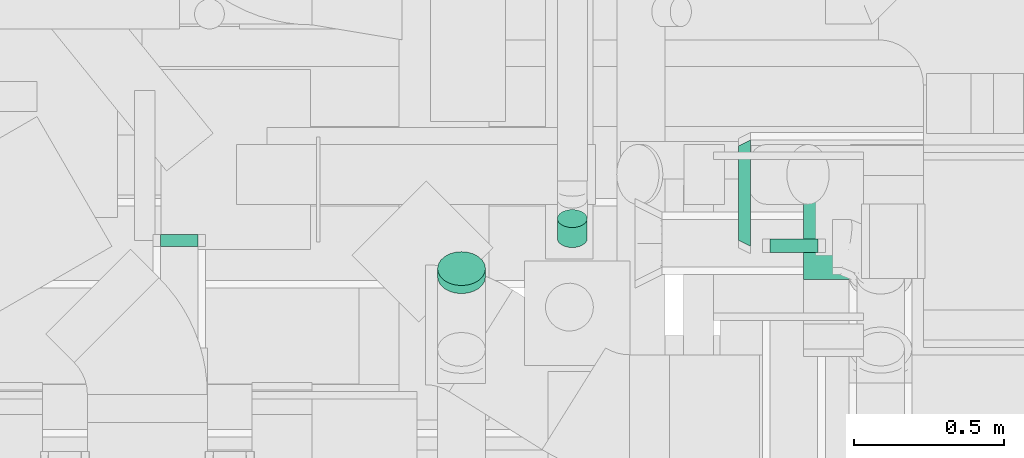
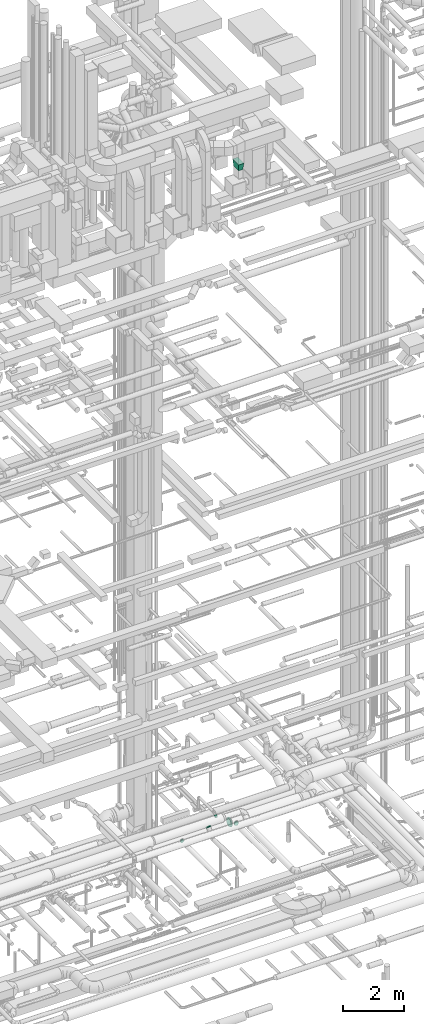
# One storey, part 328 of 337: 6 flow fittings.
"""IFC2X3 building model written with IfcOpenShell, lengths in millimetres."""

import ifcopenshell
import ifcopenshell.guid

model = None  # the IFC model being written
_history = None  # IfcOwnerHistory: only IFC2X3 demands one
_inside = {}  # id of a spatial element -> (the spatial element, [elements in it])
_under = {}  # id of a project, library or spatial element -> (it, [spatial elements below it])
_declared = {}  # id of a project -> (the project, [libraries it declares])
_typed = {}  # id of a type object -> (the type object, [elements of that type])
_made_of = {}  # id of a material, layer set ... -> (it, [elements and type objects made of it])


def new_model(schema):
    """Start an empty IFC model of exactly this schema.

    Asked for "IFC4X3", IfcOpenShell would pick the latest addendum, in which some entities
    have other attributes; the version numbers below select the first issue.
    IFC2X3 requires an IfcOwnerHistory on every rooted entity: one is made here for all.
    """
    global model, _history
    if schema == "IFC4X3":
        model = ifcopenshell.file(schema_version=(4, 3, 0, 0))
    else:
        model = ifcopenshell.file(schema=schema)
    _inside.clear()
    _under.clear()
    _declared.clear()
    _typed.clear()
    _made_of.clear()
    _history = None
    if model.schema == "IFC2X3":
        org = make("IfcOrganization", Name="unknown")
        user = make(
            "IfcPersonAndOrganization",
            ThePerson=make("IfcPerson", FamilyName="unknown"),
            TheOrganization=org,
        )
        app = make(
            "IfcApplication",
            ApplicationDeveloper=org,
            Version="unknown",
            ApplicationFullName="unknown",
            ApplicationIdentifier="unknown",
        )
        _history = make(
            "IfcOwnerHistory",
            OwningUser=user,
            OwningApplication=app,
            ChangeAction="ADDED",
            CreationDate=0,
        )
    return model


def make(cls, **values):
    """One entity of the class cls with the attributes given. An attribute that is None is left unset."""
    return model.create_entity(
        cls, **{name: value for name, value in values.items() if value is not None}
    )


def entity(cls, *values):
    """Any entity or typed value of the class cls, its attributes in the order of the schema. None: left unset."""
    e = model.create_entity(cls)
    for i, value in enumerate(values):
        if value is not None:
            e[i] = value
    return e


def rooted(cls, **values):
    """An entity with a GlobalId (a new one), such as an element, a storey or a relation."""
    return make(cls, GlobalId=ifcopenshell.guid.new(), OwnerHistory=_history, **values)


def si_unit(unit_type, name, prefix=None):
    """IfcSIUnit, for example si_unit("LENGTHUNIT", "METRE", prefix="MILLI")."""
    return make("IfcSIUnit", UnitType=unit_type, Prefix=prefix, Name=name)


def converted_unit(unit_type, name, factor, base, dimensions=None, offset=None):
    """IfcConversionBasedUnit, such as the inch: factor (a typed value) times the base unit."""
    return make(
        "IfcConversionBasedUnit"
        if offset is None
        else "IfcConversionBasedUnitWithOffset",
        ConversionOffset=offset,
        Dimensions=None
        if dimensions is None
        else entity("IfcDimensionalExponents", *dimensions),
        UnitType=unit_type,
        Name=name,
        ConversionFactor=make(
            "IfcMeasureWithUnit", ValueComponent=factor, UnitComponent=base
        ),
    )


def derived_unit(unit_type, elements):
    """IfcDerivedUnit: a product of units, each with its exponent."""
    return make(
        "IfcDerivedUnit",
        Elements=[
            make("IfcDerivedUnitElement", Unit=unit, Exponent=power)
            for unit, power in elements
        ],
        UnitType=unit_type,
    )


def assignment(units):
    """IfcUnitAssignment: the units of a project."""
    return None if units is None else make("IfcUnitAssignment", Units=units)


def point(xyz):
    """IfcCartesianPoint."""
    return None if xyz is None else make("IfcCartesianPoint", Coordinates=xyz)


def direction(xyz):
    """IfcDirection."""
    return None if xyz is None else make("IfcDirection", DirectionRatios=xyz)


def frame(location, z_axis=None, x_axis=None):
    """IfcAxis2Placement3D, a coordinate frame: its origin and axes. An axis left out is left unset."""
    return make(
        "IfcAxis2Placement3D",
        Location=point(location),
        Axis=direction(z_axis),
        RefDirection=direction(x_axis),
    )


def origin():
    """The frame at (0, 0, 0) with its axes left unset."""
    return frame((0.0, 0.0, 0.0))


def place(relative_to, where):
    """IfcLocalPlacement: puts the frame where relative to a parent placement (None: the world)."""
    return make(
        "IfcLocalPlacement", PlacementRelTo=relative_to, RelativePlacement=where
    )


def context(
    kind, dimensions, precision=None, world=None, true_north=None, identifier=None
):
    """IfcGeometricRepresentationContext, for example the 3D "Model" context."""
    return make(
        "IfcGeometricRepresentationContext",
        ContextIdentifier=identifier,
        ContextType=kind,
        CoordinateSpaceDimension=dimensions,
        Precision=precision,
        WorldCoordinateSystem=world,
        TrueNorth=true_north,
    )


def subcontext(parent, identifier, kind, view, scale=None):
    """IfcGeometricRepresentationSubContext, for example "Body" below "Model"."""
    return make(
        "IfcGeometricRepresentationSubContext",
        ContextIdentifier=identifier,
        ContextType=kind,
        ParentContext=parent,
        TargetScale=scale,
        TargetView=view,
    )


def project(units=None, contexts=None):
    """IfcProject with its units and contexts."""
    return rooted(
        "IfcProject",
        Name="project",
        RepresentationContexts=contexts,
        UnitsInContext=assignment(units),
    )


def spatial(cls, under=None, at=None, **own):
    """A site, building, storey or space (cls), placed at a placement, below another one or the project."""
    s = rooted(cls, ObjectPlacement=at, **own)
    if under is not None:
        _under.setdefault(under.id(), (under, []))[1].append(s)
    return s


def faces_of(points, faces, orient=None, outer=None):
    """IfcFace entities. A face is a list of loops; a loop is a list of indices into points, from 0.

    orient and outer hold one flag for each loop. By default every Orientation is true, the
    first loop of a face is its IfcFaceOuterBound and the others are IfcFaceBound.
    """
    made = []
    for i, loops in enumerate(faces):
        bounds = []
        for j, loop in enumerate(loops):
            is_outer = j == 0 if outer is None else outer[i][j]
            bounds.append(
                make(
                    "IfcFaceOuterBound" if is_outer else "IfcFaceBound",
                    Bound=make("IfcPolyLoop", Polygon=[points[k] for k in loop]),
                    Orientation=True if orient is None else orient[i][j],
                )
            )
        made.append(make("IfcFace", Bounds=bounds))
    return made


def faceted_brep(points, faces, orient=None, outer=None, voids=None):
    """IfcFacetedBrep: a solid bounded by flat faces; with voids (closed shells), ...WithVoids."""
    shared = [point(p) for p in points]
    hull = make("IfcClosedShell", CfsFaces=faces_of(shared, faces, orient, outer))
    if voids is None:
        return make("IfcFacetedBrep", Outer=hull)
    return make(
        "IfcFacetedBrepWithVoids",
        Outer=hull,
        Voids=[
            make(cls, CfsFaces=faces_of(shared, fs, o, b)) for cls, fs, o, b in voids
        ],
    )


def shape(context_of_items, identifier, shape_type, items):
    """IfcShapeRepresentation: the items that make up one representation, for example the "Body"."""
    return make(
        "IfcShapeRepresentation",
        ContextOfItems=context_of_items,
        RepresentationIdentifier=identifier,
        RepresentationType=shape_type,
        Items=items,
    )


def source(mapping_origin, context_of_items, identifier, shape_type, items):
    """IfcRepresentationMap: a shape defined once, which mapped items show again and again."""
    return make(
        "IfcRepresentationMap",
        MappingOrigin=mapping_origin,
        MappedRepresentation=shape(context_of_items, identifier, shape_type, items),
    )


def transform(
    local_origin,
    x_axis=None,
    y_axis=None,
    z_axis=None,
    scale=None,
    scale2=None,
    scale3=None,
    uniform=True,
):
    """IfcCartesianTransformationOperator3D, or its non-uniform kind. x_axis, y_axis, z_axis: its Axis1, 2, 3."""
    if uniform:
        return make(
            "IfcCartesianTransformationOperator3D",
            Axis1=direction(x_axis),
            Axis2=direction(y_axis),
            LocalOrigin=point(local_origin),
            Scale=scale,
            Axis3=direction(z_axis),
        )
    return make(
        "IfcCartesianTransformationOperator3DnonUniform",
        Axis1=direction(x_axis),
        Axis2=direction(y_axis),
        LocalOrigin=point(local_origin),
        Scale=scale,
        Axis3=direction(z_axis),
        Scale2=scale2,
        Scale3=scale3,
    )


def mapped(mapping_source, mapping_target):
    """IfcMappedItem: shows the shape of a source again, moved by a transform."""
    return make(
        "IfcMappedItem", MappingSource=mapping_source, MappingTarget=mapping_target
    )


def material(Name=None, Category=None):
    """IfcMaterial."""
    return make("IfcMaterial", Name=Name, Category=Category)


def made_of(thing, what):
    """Note that an element or type object is made of a material, layer set ...; save() writes the relation."""
    if what is not None:
        _made_of.setdefault(what.id(), (what, []))[1].append(thing)
    return thing


def type_object(cls, material=None, **own):
    """A type object (cls), such as IfcWallType, which elements share."""
    return made_of(rooted(cls, **own), material)


def type_shapes(of_type, sources):
    """Give a type object the sources (RepresentationMaps) that its elements show as mapped items."""
    of_type.RepresentationMaps = sources


def element(
    cls,
    number,
    at=None,
    inside=None,
    cuts=None,
    type_object=None,
    material=None,
    context=None,
    identifier="Body",
    shape_type=None,
    held_by="IfcProductDefinitionShape",
    body=None,
    shapes=None,
    **own,
):
    """One element of the class cls, such as IfcWall. Its Tag is "e" and its number.

    at: its placement. inside: the storey or other place that contains it. cuts: it is an
    opening in that element (IfcRelVoidsElement). A single representation is given by context,
    identifier, shape_type and body (its items); several are given by shapes. held_by: the class
    of the entity that holds the representations. save() writes the other relations.
    """
    e = rooted(cls, Tag="e%d" % number, ObjectPlacement=at, **own)
    if body is not None:
        shapes = [shape(context, identifier, shape_type, body)]
    if shapes is not None:
        e.Representation = make(held_by, Representations=shapes)
    if inside is not None:
        _inside.setdefault(inside.id(), (inside, []))[1].append(e)
    if cuts is not None:
        rooted(
            "IfcRelVoidsElement", RelatingBuildingElement=cuts, RelatedOpeningElement=e
        )
    if type_object is not None:
        _typed.setdefault(type_object.id(), (type_object, []))[1].append(e)
    return made_of(e, material)


def aggregate(whole, parts):
    """IfcRelAggregates: a whole, such as a stair, and the parts it consists of."""
    return rooted("IfcRelAggregates", RelatingObject=whole, RelatedObjects=parts)


def save(model, path):
    """Write the relations noted so far, then the file.

    IfcRelAggregates (storeys below a building ...), IfcRelContainedInSpatialStructure (elements
    in a storey), IfcRelDefinesByType, IfcRelAssociatesMaterial and IfcRelDeclares: one each for
    every whole, place, type object, material and project.
    """
    for whole, parts in _under.values():
        aggregate(whole, parts)
    for where, things in _inside.values():
        rooted(
            "IfcRelContainedInSpatialStructure",
            RelatedElements=things,
            RelatingStructure=where,
        )
    for kind, things in _typed.values():
        rooted("IfcRelDefinesByType", RelatedObjects=things, RelatingType=kind)
    for what, things in _made_of.values():
        rooted("IfcRelAssociatesMaterial", RelatedObjects=things, RelatingMaterial=what)
    for by, libraries in _declared.values():
        rooted("IfcRelDeclares", RelatingContext=by, RelatedDefinitions=libraries)
    model.write(path)


model = new_model("IFC2X3")

# Units and contexts
model_context = context("Model", 3, precision=0.01, world=origin(), true_north=direction((6.12303176911189e-17, 1.0)))
body_context = subcontext(model_context, "Body", "Model", "MODEL_VIEW")
ifc_project = project(units=[si_unit("LENGTHUNIT", "METRE", prefix="MILLI"), si_unit("AREAUNIT", "SQUARE_METRE"), si_unit("VOLUMEUNIT", "CUBIC_METRE"), converted_unit("PLANEANGLEUNIT", "DEGREE", entity("IfcRatioMeasure", 0.0174532925199433), si_unit("PLANEANGLEUNIT", "RADIAN"), dimensions=[0, 0, 0, 0, 0, 0, 0]), si_unit("MASSUNIT", "GRAM", prefix="KILO"), derived_unit("MASSDENSITYUNIT", [(si_unit("MASSUNIT", "GRAM", prefix="KILO"), 1), (si_unit("LENGTHUNIT", "METRE"), -3)]), derived_unit("MOMENTOFINERTIAUNIT", [(si_unit("LENGTHUNIT", "METRE"), 4)]), si_unit("TIMEUNIT", "SECOND"), si_unit("FREQUENCYUNIT", "HERTZ"), si_unit("THERMODYNAMICTEMPERATUREUNIT", "DEGREE_CELSIUS"), derived_unit("THERMALTRANSMITTANCEUNIT", [(si_unit("MASSUNIT", "GRAM", prefix="KILO"), 1), (si_unit("THERMODYNAMICTEMPERATUREUNIT", "KELVIN"), -1), (si_unit("TIMEUNIT", "SECOND"), -3)]), derived_unit("VOLUMETRICFLOWRATEUNIT", [(si_unit("LENGTHUNIT", "METRE"), 3), (si_unit("TIMEUNIT", "SECOND"), -1)]), derived_unit("MASSFLOWRATEUNIT", [(si_unit("MASSUNIT", "GRAM", prefix="KILO"), 1), (si_unit("TIMEUNIT", "SECOND"), -1)]), derived_unit("ROTATIONALFREQUENCYUNIT", [(si_unit("TIMEUNIT", "SECOND"), -1)]), si_unit("ELECTRICCURRENTUNIT", "AMPERE"), si_unit("ELECTRICVOLTAGEUNIT", "VOLT"), si_unit("POWERUNIT", "WATT"), si_unit("FORCEUNIT", "NEWTON", prefix="KILO"), si_unit("ILLUMINANCEUNIT", "LUX"), si_unit("LUMINOUSFLUXUNIT", "LUMEN"), si_unit("LUMINOUSINTENSITYUNIT", "CANDELA"), derived_unit("USERDEFINED", [(si_unit("MASSUNIT", "GRAM", prefix="KILO"), -1), (si_unit("LENGTHUNIT", "METRE"), -2), (si_unit("TIMEUNIT", "SECOND"), 3), (si_unit("LUMINOUSFLUXUNIT", "LUMEN"), 1)]), derived_unit("LINEARVELOCITYUNIT", [(si_unit("LENGTHUNIT", "METRE"), 1), (si_unit("TIMEUNIT", "SECOND"), -1)]), si_unit("PRESSUREUNIT", "PASCAL"), derived_unit("USERDEFINED", [(si_unit("LENGTHUNIT", "METRE"), -2), (si_unit("MASSUNIT", "GRAM", prefix="KILO"), 1), (si_unit("TIMEUNIT", "SECOND"), -2)]), derived_unit("LINEARFORCEUNIT", [(si_unit("MASSUNIT", "GRAM", prefix="KILO"), 1), (si_unit("LENGTHUNIT", "METRE"), 1), (si_unit("TIMEUNIT", "SECOND"), -2), (si_unit("LENGTHUNIT", "METRE"), -1)]), derived_unit("PLANARFORCEUNIT", [(si_unit("MASSUNIT", "GRAM", prefix="KILO"), 1), (si_unit("LENGTHUNIT", "METRE"), 1), (si_unit("TIMEUNIT", "SECOND"), -2), (si_unit("LENGTHUNIT", "METRE"), -2)])], contexts=[model_context])

# Site, building, storey
site_placement = place(None, origin())
site = spatial("IfcSite", under=ifc_project, at=site_placement, CompositionType="ELEMENT")
building_placement = place(site_placement, origin())
building = spatial("IfcBuilding", under=site, at=building_placement, CompositionType="ELEMENT")
storey_placement = place(building_placement, origin())
storey = spatial("IfcBuildingStorey", under=building, at=storey_placement, CompositionType="ELEMENT", Elevation=0.0)

# Flow fittings
ifc_material = material()
duct_fitting_type_1 = type_object("IfcDuctFittingType", PredefinedType="NOTDEFINED", material=ifc_material)
shared_shape_1 = source(origin(), body_context, "Body", "Brep", [
    faceted_brep([(300.0, -60.0, 120.0), (300.0, -60.0, -200.0), (300.0, 100.0, -200.0), (300.0, 100.0, 120.0), (0.0, -100.0, 200.0), (0.0, 100.0, 200.0), (0.0, 100.0, -200.0), (0.0, -100.0, -200.0)], [[[0, 1, 2, 3]], [[4, 5, 6, 7]], [[4, 7, 1, 0]], [[7, 6, 2, 1]], [[6, 5, 3, 2]], [[5, 4, 0, 3]]]),
])
type_shapes(duct_fitting_type_1, [shared_shape_1])
flow_fitting_1_placement = place(storey_placement, frame((61570.03, 9188.6, 29600.0), z_axis=(0.0, -1.0, 0.0), x_axis=(0.0, 0.0, -1.0)))
element("IfcFlowFitting", 1, at=flow_fitting_1_placement, inside=storey, type_object=duct_fitting_type_1, material=ifc_material, context=body_context, shape_type="MappedRepresentation", body=[
    mapped(shared_shape_1, transform((0.0, 0.0, 0.0), scale=1.0)),
])
duct_fitting_type_2 = type_object("IfcDuctFittingType", PredefinedType="NOTDEFINED", material=ifc_material)
shared_shape_2 = source(origin(), body_context, "Body", "Brep", [
    faceted_brep([(20.0, 0.0, -80.0), (20.0, 20.71, -77.27), (20.0, 40.0, -69.28), (20.0, 56.57, -56.57), (20.0, 69.28, -40.0), (20.0, 77.27, -20.71), (20.0, 80.0, 0.0), (20.0, 77.27, 20.71), (20.0, 69.28, 40.0), (20.0, 56.57, 56.57), (20.0, 40.0, 69.28), (20.0, 20.71, 77.27), (20.0, 0.0, 80.0), (20.0, -20.71, 77.27), (20.0, -40.0, 69.28), (20.0, -56.57, 56.57), (20.0, -69.28, 40.0), (20.0, -77.27, 20.71), (20.0, -80.0, 0.0), (20.0, -77.27, -20.71), (20.0, -69.28, -40.0), (20.0, -56.57, -56.57), (20.0, -40.0, -69.28), (20.0, -20.71, -77.27), (0.0, 0.0, 80.0), (-25.15, 0.0, 80.0), (-25.15, -20.71, 77.27), (0.0, -20.71, 77.27), (-25.15, -40.0, 69.28), (0.0, -40.0, 69.28), (0.0, -56.57, 56.57), (-25.15, -56.57, 56.57), (0.0, -69.28, 40.0), (-25.15, -69.28, 40.0), (-25.15, -77.27, 20.71), (0.0, -77.27, 20.71), (-25.15, -80.0, 0.0), (0.0, -80.0, 0.0), (-25.15, -77.27, -20.71), (0.0, -77.27, -20.71), (-25.15, -69.28, -40.0), (0.0, -69.28, -40.0), (0.0, -56.57, -56.57), (-25.15, -56.57, -56.57), (0.0, -40.0, -69.28), (-25.15, -40.0, -69.28), (-25.15, -20.71, -77.27), (0.0, -20.71, -77.27), (-25.15, 0.0, -80.0), (0.0, 0.0, -80.0), (-25.15, 20.71, -77.27), (0.0, 20.71, -77.27), (-25.15, 40.0, -69.28), (0.0, 40.0, -69.28), (0.0, 56.57, -56.57), (-25.15, 56.57, -56.57), (0.0, 69.28, -40.0), (-25.15, 69.28, -40.0), (-25.15, 77.27, -20.71), (0.0, 77.27, -20.71), (-25.15, 80.0, 0.0), (0.0, 80.0, 0.0), (-25.15, 77.27, 20.71), (0.0, 77.27, 20.71), (-25.15, 69.28, 40.0), (0.0, 69.28, 40.0), (0.0, 56.57, 56.57), (-25.15, 56.57, 56.57), (0.0, 40.0, 69.28), (-25.15, 40.0, 69.28), (-25.15, 20.71, 77.27), (0.0, 20.71, 77.27)], [[[0, 1, 2, 3, 4, 5, 6, 7, 8, 9, 10, 11, 12, 13, 14, 15, 16, 17, 18, 19, 20, 21, 22, 23]], [[13, 12, 24, 25, 26, 27]], [[14, 13, 27, 26, 28, 29]], [[30, 15, 14, 29, 28, 31]], [[17, 16, 32, 33, 34, 35]], [[18, 17, 35, 34, 36, 37]], [[32, 16, 15, 30, 31, 33]], [[19, 18, 37, 36, 38, 39]], [[20, 19, 39, 38, 40, 41]], [[42, 21, 20, 41, 40, 43]], [[23, 22, 44, 45, 46, 47]], [[0, 23, 47, 46, 48, 49]], [[44, 22, 21, 42, 43, 45]], [[1, 0, 49, 48, 50, 51]], [[2, 1, 51, 50, 52, 53]], [[54, 3, 2, 53, 52, 55]], [[5, 4, 56, 57, 58, 59]], [[6, 5, 59, 58, 60, 61]], [[56, 4, 3, 54, 55, 57]], [[7, 6, 61, 60, 62, 63]], [[8, 7, 63, 62, 64, 65]], [[66, 9, 8, 65, 64, 67]], [[11, 10, 68, 69, 70, 71]], [[12, 11, 71, 70, 25, 24]], [[68, 10, 9, 66, 67, 69]], [[46, 45, 43, 40, 38, 36, 34, 33, 31, 28, 26, 25, 70, 69, 67, 64, 62, 60, 58, 57, 55, 52, 50, 48]]]),
])
type_shapes(duct_fitting_type_2, [shared_shape_2])
flow_fitting_2_placement = place(storey_placement, frame((61438.02, 9098.38, 3100.0), z_axis=(0.0, 0.0, -1.0), x_axis=(0.0, -1.0, 0.0)))
element("IfcFlowFitting", 2, at=flow_fitting_2_placement, inside=storey, type_object=duct_fitting_type_2, material=ifc_material, context=body_context, shape_type="MappedRepresentation", body=[
    mapped(shared_shape_2, transform((0.0, 0.0, 0.0), scale=1.0)),
])
duct_fitting_type_3 = type_object("IfcDuctFittingType", PredefinedType="NOTDEFINED", material=ifc_material)
shared_shape_3 = source(origin(), body_context, "Body", "Brep", [
    faceted_brep([(20.0, 0.0, -62.5), (20.0, 16.18, -60.37), (20.0, 31.25, -54.13), (20.0, 44.19, -44.19), (20.0, 54.13, -31.25), (20.0, 60.37, -16.18), (20.0, 62.5, 0.0), (20.0, 60.37, 16.18), (20.0, 54.13, 31.25), (20.0, 44.19, 44.19), (20.0, 31.25, 54.13), (20.0, 16.18, 60.37), (20.0, 0.0, 62.5), (20.0, -16.18, 60.37), (20.0, -31.25, 54.13), (20.0, -44.19, 44.19), (20.0, -54.13, 31.25), (20.0, -60.37, 16.18), (20.0, -62.5, 0.0), (20.0, -60.37, -16.18), (20.0, -54.13, -31.25), (20.0, -44.19, -44.19), (20.0, -31.25, -54.13), (20.0, -16.18, -60.37), (0.0, 0.0, 62.5), (-19.04, 0.0, 62.5), (-19.04, -16.18, 60.37), (0.0, -16.18, 60.37), (-19.04, -31.25, 54.13), (0.0, -31.25, 54.13), (0.0, -44.19, 44.19), (-19.04, -44.19, 44.19), (0.0, -54.13, 31.25), (-19.04, -54.13, 31.25), (-19.04, -60.37, 16.18), (0.0, -60.37, 16.18), (-19.04, -62.5, 0.0), (0.0, -62.5, 0.0), (-19.04, -60.37, -16.18), (0.0, -60.37, -16.18), (-19.04, -54.13, -31.25), (0.0, -54.13, -31.25), (0.0, -44.19, -44.19), (-19.04, -44.19, -44.19), (0.0, -31.25, -54.13), (-19.04, -31.25, -54.13), (-19.04, -16.18, -60.37), (0.0, -16.18, -60.37), (-19.04, 0.0, -62.5), (0.0, 0.0, -62.5), (-19.04, 16.18, -60.37), (0.0, 16.18, -60.37), (-19.04, 31.25, -54.13), (0.0, 31.25, -54.13), (0.0, 44.19, -44.19), (-19.04, 44.19, -44.19), (0.0, 54.13, -31.25), (-19.04, 54.13, -31.25), (-19.04, 60.37, -16.18), (0.0, 60.37, -16.18), (-19.04, 62.5, 0.0), (0.0, 62.5, 0.0), (-19.04, 60.37, 16.18), (0.0, 60.37, 16.18), (-19.04, 54.13, 31.25), (0.0, 54.13, 31.25), (0.0, 44.19, 44.19), (-19.04, 44.19, 44.19), (0.0, 31.25, 54.13), (-19.04, 31.25, 54.13), (-19.04, 16.18, 60.37), (0.0, 16.18, 60.37)], [[[0, 1, 2, 3, 4, 5, 6, 7, 8, 9, 10, 11, 12, 13, 14, 15, 16, 17, 18, 19, 20, 21, 22, 23]], [[13, 12, 24, 25, 26, 27]], [[14, 13, 27, 26, 28, 29]], [[30, 15, 14, 29, 28, 31]], [[17, 16, 32, 33, 34, 35]], [[18, 17, 35, 34, 36, 37]], [[32, 16, 15, 30, 31, 33]], [[19, 18, 37, 36, 38, 39]], [[20, 19, 39, 38, 40, 41]], [[42, 21, 20, 41, 40, 43]], [[23, 22, 44, 45, 46, 47]], [[0, 23, 47, 46, 48, 49]], [[44, 22, 21, 42, 43, 45]], [[1, 0, 49, 48, 50, 51]], [[2, 1, 51, 50, 52, 53]], [[54, 3, 2, 53, 52, 55]], [[5, 4, 56, 57, 58, 59]], [[6, 5, 59, 58, 60, 61]], [[56, 4, 3, 54, 55, 57]], [[7, 6, 61, 60, 62, 63]], [[8, 7, 63, 62, 64, 65]], [[66, 9, 8, 65, 64, 67]], [[11, 10, 68, 69, 70, 71]], [[12, 11, 71, 70, 25, 24]], [[68, 10, 9, 66, 67, 69]], [[46, 45, 43, 40, 38, 36, 34, 33, 31, 28, 26, 25, 70, 69, 67, 64, 62, 60, 58, 57, 55, 52, 50, 48]]]),
])
type_shapes(duct_fitting_type_3, [shared_shape_3])
flow_fitting_3_placement = place(storey_placement, frame((59387.05, 9118.38, 3099.97), z_axis=(0.0, -1.21915181874873e-05, -1.0), x_axis=(0.0, -1.0, 1.21915181868247e-05)))
element("IfcFlowFitting", 3, at=flow_fitting_3_placement, inside=storey, type_object=duct_fitting_type_3, material=ifc_material, context=body_context, shape_type="MappedRepresentation", body=[
    mapped(shared_shape_3, transform((0.0, 0.0, 0.0), scale=1.0)),
])
duct_fitting_type_4 = type_object("IfcDuctFittingType", PredefinedType="NOTDEFINED", material=ifc_material)
shared_shape_4 = source(origin(), body_context, "Body", "Brep", [
    faceted_brep([(32.76, 12.94, -48.3), (32.76, 25.0, -43.3), (32.76, 35.36, -35.36), (32.76, 43.3, -25.0), (32.76, 48.3, -12.94), (32.76, 50.0, 0.0), (32.76, 48.3, 12.94), (32.76, 43.3, 25.0), (32.76, 35.36, 35.36), (32.76, 25.0, 43.3), (32.76, 12.94, 48.3), (32.76, 0.0, 50.0), (32.76, -12.94, 48.3), (32.76, -25.0, 43.3), (32.76, -35.36, 35.36), (32.76, -43.3, 25.0), (32.76, -48.3, 12.94), (32.76, -50.0, 0.0), (32.76, -48.3, -12.94), (32.76, -43.3, -25.0), (32.76, -35.36, -35.36), (32.76, -25.0, -43.3), (32.76, -12.94, -48.3), (32.76, 0.0, -50.0), (0.0, 0.0, 50.0), (0.0, 12.94, 48.3), (-50.77, 12.94, 48.3), (-50.77, 0.0, 50.0), (0.0, 25.0, 43.3), (-50.77, 25.0, 43.3), (0.0, 35.36, 35.36), (-50.77, 35.36, 35.36), (0.0, 43.3, 25.0), (0.0, 48.3, 12.94), (-50.77, 48.3, 12.94), (-50.77, 43.3, 25.0), (0.0, 50.0, 0.0), (-50.77, 50.0, 0.0), (0.0, 48.3, -12.94), (-50.77, 48.3, -12.94), (0.0, 43.3, -25.0), (-50.77, 43.3, -25.0), (0.0, 35.36, -35.36), (-50.77, 35.36, -35.36), (0.0, 25.0, -43.3), (0.0, 12.94, -48.3), (-50.77, 12.94, -48.3), (-50.77, 25.0, -43.3), (0.0, 0.0, -50.0), (-50.77, 0.0, -50.0), (0.0, -12.94, -48.3), (-50.77, -12.94, -48.3), (0.0, -25.0, -43.3), (-50.77, -25.0, -43.3), (0.0, -35.36, -35.36), (-50.77, -35.36, -35.36), (0.0, -50.0, 0.0), (-50.77, -50.0, 0.0), (-50.77, -48.3, -12.94), (0.0, -48.3, -12.94), (-50.77, -43.3, -25.0), (0.0, -43.3, -25.0), (0.0, -48.3, 12.94), (-50.77, -48.3, 12.94), (0.0, -43.3, 25.0), (-50.77, -43.3, 25.0), (0.0, -35.36, 35.36), (-50.77, -35.36, 35.36), (0.0, -25.0, 43.3), (0.0, -12.94, 48.3), (-50.77, -12.94, 48.3), (-50.77, -25.0, 43.3)], [[[0, 1, 2, 3, 4, 5, 6, 7, 8, 9, 10, 11, 12, 13, 14, 15, 16, 17, 18, 19, 20, 21, 22, 23]], [[24, 11, 10, 25, 26, 27]], [[25, 10, 9, 28, 29, 26]], [[28, 9, 8, 30, 31, 29]], [[32, 7, 6, 33, 34, 35]], [[33, 6, 5, 36, 37, 34]], [[30, 8, 7, 32, 35, 31]], [[36, 5, 4, 38, 39, 37]], [[38, 4, 3, 40, 41, 39]], [[40, 3, 2, 42, 43, 41]], [[44, 1, 0, 45, 46, 47]], [[48, 49, 46, 45, 0, 23]], [[42, 2, 1, 44, 47, 43]], [[48, 23, 22, 50, 51, 49]], [[50, 22, 21, 52, 53, 51]], [[52, 21, 20, 54, 55, 53]], [[18, 17, 56, 57, 58, 59]], [[19, 18, 59, 58, 60, 61]], [[54, 20, 19, 61, 60, 55]], [[56, 17, 16, 62, 63, 57]], [[62, 16, 15, 64, 65, 63]], [[64, 15, 14, 66, 67, 65]], [[68, 13, 12, 69, 70, 71]], [[69, 12, 11, 24, 27, 70]], [[66, 14, 13, 68, 71, 67]], [[49, 51, 53, 55, 60, 58, 57, 63, 65, 67, 71, 70, 27, 26, 29, 31, 35, 34, 37, 39, 41, 43, 47, 46]]]),
])
type_shapes(duct_fitting_type_4, [shared_shape_4])
flow_fitting_4_placement = place(storey_placement, frame((60698.4, 9164.96, 3611.63), z_axis=(0.0, 0.60181502315207, -0.798635510047276), x_axis=(0.0, 0.798635510047284, 0.60181502315206)))
element("IfcFlowFitting", 4, at=flow_fitting_4_placement, inside=storey, type_object=duct_fitting_type_4, material=ifc_material, context=body_context, shape_type="MappedRepresentation", body=[
    mapped(shared_shape_4, transform((0.0, 0.0, 0.0), scale=1.0)),
])
duct_fitting_type_5 = type_object("IfcDuctFittingType", PredefinedType="NOTDEFINED", material=ifc_material)
shared_shape_5 = source(origin(), body_context, "Body", "Brep", [
    faceted_brep([(31.84, 0.0, -80.0), (31.84, 20.71, -77.27), (31.84, 40.0, -69.28), (31.84, 56.57, -56.57), (31.84, 69.28, -40.0), (31.84, 77.27, -20.71), (31.84, 80.0, 0.0), (31.84, 77.27, 20.71), (31.84, 69.28, 40.0), (31.84, 56.57, 56.57), (31.84, 40.0, 69.28), (31.84, 20.71, 77.27), (31.84, 0.0, 80.0), (31.84, -20.71, 77.27), (31.84, -40.0, 69.28), (31.84, -56.57, 56.57), (31.84, -69.28, 40.0), (31.84, -77.27, 20.71), (31.84, -80.0, 0.0), (31.84, -77.27, -20.71), (31.84, -69.28, -40.0), (31.84, -56.57, -56.57), (31.84, -40.0, -69.28), (31.84, -20.71, -77.27), (0.0, 0.0, 80.0), (-6.1, 0.0, 80.0), (-6.1, -20.71, 77.27), (0.0, -20.71, 77.27), (-6.1, -40.0, 69.28), (0.0, -40.0, 69.28), (0.0, -56.57, 56.57), (-6.1, -56.57, 56.57), (0.0, -69.28, 40.0), (-6.1, -69.28, 40.0), (-6.1, -77.27, 20.71), (0.0, -77.27, 20.71), (-6.1, -80.0, 0.0), (0.0, -80.0, 0.0), (-6.1, -77.27, -20.71), (0.0, -77.27, -20.71), (-6.1, -69.28, -40.0), (0.0, -69.28, -40.0), (0.0, -56.57, -56.57), (-6.1, -56.57, -56.57), (0.0, -40.0, -69.28), (-6.1, -40.0, -69.28), (-6.1, -20.71, -77.27), (0.0, -20.71, -77.27), (-6.1, 0.0, -80.0), (0.0, 0.0, -80.0), (-6.1, 20.71, -77.27), (0.0, 20.71, -77.27), (-6.1, 40.0, -69.28), (0.0, 40.0, -69.28), (0.0, 56.57, -56.57), (-6.1, 56.57, -56.57), (0.0, 69.28, -40.0), (-6.1, 69.28, -40.0), (-6.1, 77.27, -20.71), (0.0, 77.27, -20.71), (-6.1, 80.0, 0.0), (0.0, 80.0, 0.0), (-6.1, 77.27, 20.71), (0.0, 77.27, 20.71), (-6.1, 69.28, 40.0), (0.0, 69.28, 40.0), (0.0, 56.57, 56.57), (-6.1, 56.57, 56.57), (0.0, 40.0, 69.28), (-6.1, 40.0, 69.28), (-6.1, 20.71, 77.27), (0.0, 20.71, 77.27)], [[[0, 1, 2, 3, 4, 5, 6, 7, 8, 9, 10, 11, 12, 13, 14, 15, 16, 17, 18, 19, 20, 21, 22, 23]], [[13, 12, 24, 25, 26, 27]], [[14, 13, 27, 26, 28, 29]], [[30, 15, 14, 29, 28, 31]], [[17, 16, 32, 33, 34, 35]], [[18, 17, 35, 34, 36, 37]], [[32, 16, 15, 30, 31, 33]], [[19, 18, 37, 36, 38, 39]], [[20, 19, 39, 38, 40, 41]], [[42, 21, 20, 41, 40, 43]], [[23, 22, 44, 45, 46, 47]], [[0, 23, 47, 46, 48, 49]], [[44, 22, 21, 42, 43, 45]], [[1, 0, 49, 48, 50, 51]], [[2, 1, 51, 50, 52, 53]], [[54, 3, 2, 53, 52, 55]], [[5, 4, 56, 57, 58, 59]], [[6, 5, 59, 58, 60, 61]], [[56, 4, 3, 54, 55, 57]], [[7, 6, 61, 60, 62, 63]], [[8, 7, 63, 62, 64, 65]], [[66, 9, 8, 65, 64, 67]], [[11, 10, 68, 69, 70, 71]], [[12, 11, 71, 70, 25, 24]], [[68, 10, 9, 66, 67, 69]], [[46, 45, 43, 40, 38, 36, 34, 33, 31, 28, 26, 25, 70, 69, 67, 64, 62, 60, 58, 57, 55, 52, 50, 48]]]),
])
type_shapes(duct_fitting_type_5, [shared_shape_5])
flow_fitting_5_placement = place(storey_placement, frame((60328.78, 9019.73, 3412.17), z_axis=(0.0, 0.707106781186559, -0.707106781186536), x_axis=(0.0, -0.707106781186533, -0.707106781186562)))
element("IfcFlowFitting", 5, at=flow_fitting_5_placement, inside=storey, type_object=duct_fitting_type_5, material=ifc_material, context=body_context, shape_type="MappedRepresentation", body=[
    mapped(shared_shape_5, transform((0.0, 0.0, 0.0), scale=1.0)),
])
duct_fitting_type_6 = type_object("IfcDuctFittingType", PredefinedType="NOTDEFINED", material=ifc_material)
shared_shape_6 = source(origin(), body_context, "Body", "Brep", [
    faceted_brep([(40.0, -45.94, -171.45), (40.0, 0.0, -177.5), (40.0, 45.94, -171.45), (40.0, 88.75, -153.72), (40.0, 125.51, -125.51), (40.0, 153.72, -88.75), (40.0, 171.45, -45.94), (40.0, 177.5, 0.0), (40.0, 171.45, 45.94), (40.0, 153.72, 88.75), (40.0, 125.51, 125.51), (40.0, 88.75, 153.72), (40.0, 45.94, 171.45), (40.0, 0.0, 177.5), (40.0, -45.94, 171.45), (40.0, -88.75, 153.72), (40.0, -125.51, 125.51), (40.0, -153.72, 88.75), (40.0, -171.45, 45.94), (40.0, -177.5, 0.0), (40.0, -171.45, -45.94), (40.0, -153.72, -88.75), (40.0, -125.51, -125.51), (40.0, -88.75, -153.72), (0.0, 152.13, -40.76), (0.0, 136.4, -78.75), (0.0, 111.37, -111.37), (0.0, 78.75, -136.4), (0.0, 40.76, -152.13), (0.0, 0.0, -157.5), (0.0, -40.76, -152.13), (0.0, -78.75, -136.4), (0.0, -111.37, -111.37), (0.0, -136.4, -78.75), (0.0, -152.13, -40.76), (0.0, -157.5, 0.0), (0.0, -152.13, 40.76), (0.0, -136.4, 78.75), (0.0, -111.37, 111.37), (0.0, -78.75, 136.4), (0.0, -40.76, 152.13), (0.0, 0.0, 157.5), (0.0, 40.76, 152.13), (0.0, 78.75, 136.4), (0.0, 111.37, 111.37), (0.0, 136.4, 78.75), (0.0, 152.13, 40.76), (0.0, 157.5, 0.0), (20.0, 154.75, 64.1), (20.0, 132.89, 101.97), (20.76, 164.71, 32.44), (16.7, 165.85, 0.0), (20.76, 32.44, 164.71), (20.0, 101.97, 132.89), (20.0, 64.1, 154.75), (16.7, 0.0, 165.85), (20.0, -64.1, 154.75), (20.0, -101.97, 132.89), (20.76, -32.44, 164.71), (20.76, -164.71, 32.44), (20.0, -132.89, 101.97), (20.0, -154.75, 64.1), (16.7, -165.85, 0.0), (20.0, -154.75, -64.1), (20.0, -132.89, -101.97), (20.76, -164.71, -32.44), (20.76, -32.44, -164.71), (20.0, -101.97, -132.89), (20.0, -64.1, -154.75), (16.7, 0.0, -165.85), (20.0, 64.1, -154.75), (20.0, 101.97, -132.89), (20.76, 32.44, -164.71), (20.76, 164.71, -32.44), (20.0, 132.89, -101.97), (20.0, 154.75, -64.1)], [[[0, 1, 2, 3, 4, 5, 6, 7, 8, 9, 10, 11, 12, 13, 14, 15, 16, 17, 18, 19, 20, 21, 22, 23]], [[24, 25, 26, 27, 28, 29, 30, 31, 32, 33, 34, 35, 36, 37, 38, 39, 40, 41, 42, 43, 44, 45, 46, 47]], [[48, 45, 49]], [[48, 8, 50]], [[46, 45, 48]], [[46, 48, 50]], [[51, 47, 50, 7]], [[48, 49, 9]], [[47, 46, 50]], [[8, 48, 9]], [[49, 10, 9]], [[41, 52, 42]], [[53, 49, 44]], [[52, 12, 54]], [[54, 43, 42]], [[11, 54, 12]], [[42, 52, 54]], [[13, 12, 52]], [[53, 11, 10]], [[54, 53, 43]], [[7, 50, 8]], [[54, 11, 53]], [[49, 53, 10]], [[43, 53, 44]], [[44, 49, 45]], [[13, 52, 41, 55]], [[56, 39, 57]], [[56, 14, 58]], [[40, 39, 56]], [[40, 56, 58]], [[55, 41, 58, 13]], [[56, 57, 15]], [[41, 40, 58]], [[14, 56, 15]], [[57, 16, 15]], [[35, 59, 36]], [[60, 57, 38]], [[59, 18, 61]], [[61, 37, 36]], [[17, 61, 18]], [[36, 59, 61]], [[19, 18, 59]], [[60, 17, 16]], [[61, 60, 37]], [[13, 58, 14]], [[61, 17, 60]], [[57, 60, 16]], [[37, 60, 38]], [[38, 57, 39]], [[19, 59, 35, 62]], [[63, 33, 64]], [[63, 20, 65]], [[34, 33, 63]], [[34, 63, 65]], [[62, 35, 65, 19]], [[63, 64, 21]], [[35, 34, 65]], [[20, 63, 21]], [[64, 22, 21]], [[29, 66, 30]], [[67, 64, 32]], [[66, 0, 68]], [[68, 31, 30]], [[23, 68, 0]], [[30, 66, 68]], [[1, 0, 66]], [[67, 23, 22]], [[68, 67, 31]], [[19, 65, 20]], [[68, 23, 67]], [[64, 67, 22]], [[31, 67, 32]], [[32, 64, 33]], [[1, 66, 29, 69]], [[70, 27, 71]], [[70, 2, 72]], [[28, 27, 70]], [[28, 70, 72]], [[69, 29, 72, 1]], [[70, 71, 3]], [[29, 28, 72]], [[2, 70, 3]], [[71, 4, 3]], [[47, 73, 24]], [[74, 71, 26]], [[73, 6, 75]], [[75, 25, 24]], [[5, 75, 6]], [[24, 73, 75]], [[7, 6, 73]], [[74, 5, 4]], [[75, 74, 25]], [[1, 72, 2]], [[75, 5, 74]], [[71, 74, 4]], [[25, 74, 26]], [[26, 71, 27]], [[7, 73, 47, 51]]]),
])
type_shapes(duct_fitting_type_6, [shared_shape_6])
flow_fitting_6_placement = place(storey_placement, frame((61253.27, 9275.88, 3100.0)))
element("IfcFlowFitting", 6, at=flow_fitting_6_placement, inside=storey, type_object=duct_fitting_type_6, material=ifc_material, context=body_context, shape_type="MappedRepresentation", body=[
    mapped(shared_shape_6, transform((0.0, 0.0, 0.0), scale=1.0)),
])

save(model, "model.ifc")
